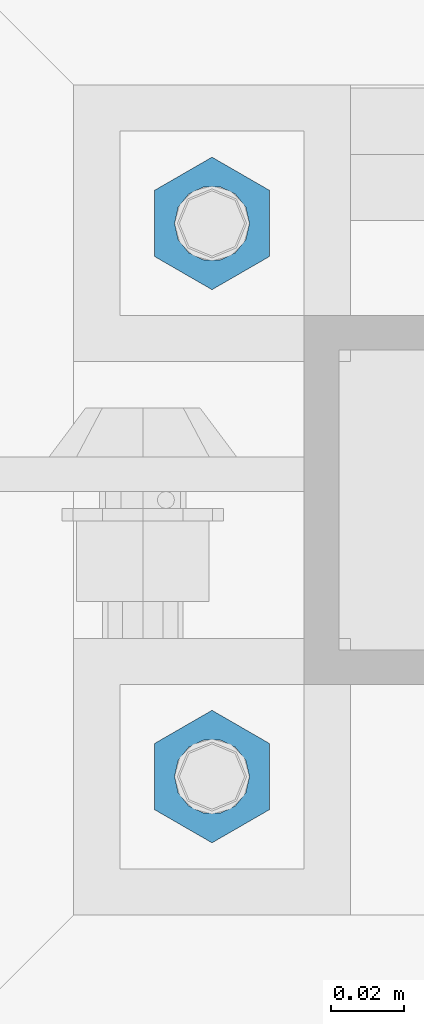
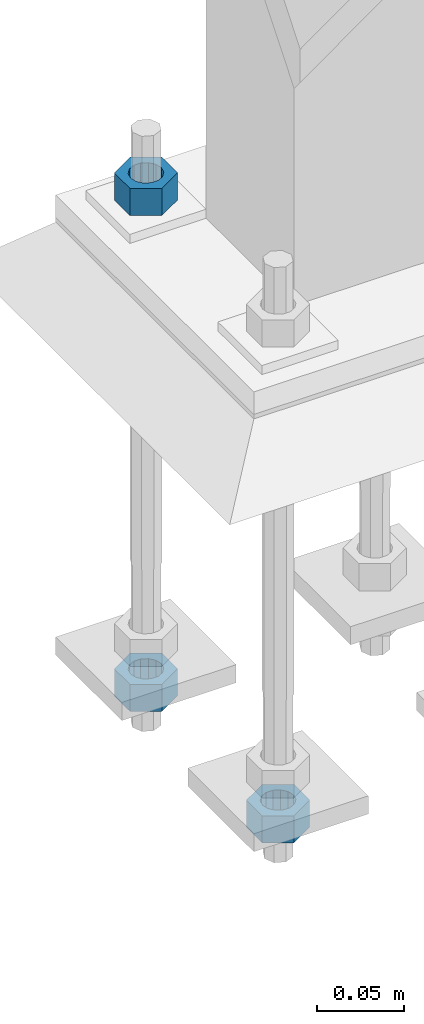
# One storey, part 1676 of 3843: 3 columns, 1 element without a shape of its own.
"""IFC2X3 building model written with IfcOpenShell, lengths in millimetres."""

from ifc_helpers import new_model, si_unit, frame, origin_with_axes, place, context, subcontext, project, spatial, faceted_brep, material, type_object, element, aggregate, save


model = new_model("IFC2X3")

# Units and contexts
model_context = context("Model", 3, precision=1e-05, world=origin_with_axes())
body_context = subcontext(model_context, "Body", "Model", "MODEL_VIEW")
ifc_project = project(units=[si_unit("LENGTHUNIT", "METRE", prefix="MILLI"), si_unit("AREAUNIT", "SQUARE_METRE"), si_unit("VOLUMEUNIT", "CUBIC_METRE"), si_unit("MASSUNIT", "GRAM", prefix="KILO"), si_unit("TIMEUNIT", "SECOND"), si_unit("PLANEANGLEUNIT", "RADIAN"), si_unit("SOLIDANGLEUNIT", "STERADIAN"), si_unit("THERMODYNAMICTEMPERATUREUNIT", "DEGREE_CELSIUS"), si_unit("LUMINOUSINTENSITYUNIT", "LUMEN")], contexts=[model_context])

# Site, building, storey
site_placement = place(None, origin_with_axes())
site = spatial("IfcSite", under=ifc_project, at=site_placement, CompositionType="ELEMENT")
building_placement = place(site_placement, origin_with_axes())
building = spatial("IfcBuilding", under=site, at=building_placement, Name="Undefined", CompositionType="ELEMENT")
storey_placement = place(building_placement, origin_with_axes())
storey = spatial("IfcBuildingStorey", under=building, at=storey_placement, Name="Undefined", CompositionType="ELEMENT", Elevation=0.0)

# Assembly, columns
assembly_placement = place(storey_placement, origin_with_axes())
assembly = element("IfcElementAssembly", 1, at=assembly_placement, inside=storey, Name="TEMPLATE", AssemblyPlace="NOTDEFINED", PredefinedType="RIGID_FRAME")
ifc_material = material(Name="STEEL/A36")
column_type = type_object("IfcColumnType", Name="3/4_HEAVY_HEX_NUT", PredefinedType="NOTDEFINED")
column_1_placement = place(assembly_placement, frame((38744.525, 33769.3, 29756.1), z_axis=(1.0, 0.0, 0.0), x_axis=(0.0, 0.0, -1.0)))
column_1 = element("IfcColumn", 2, at=column_1_placement, type_object=column_type, material=ifc_material, Name="NUT", ObjectType="3/4_HEAVY_HEX_NUT", context=body_context, shape_type="Brep", body=[
    faceted_brep([(0.0, -18.2600002288818, 0.0), (0.0, -9.13000011444092, -15.8100004196167), (19.0500000000029, -9.13000011444092, -15.8100004196167), (19.0500000000029, -18.2600002288818, 0.0), (0.0, 9.13000011444092, -15.8100004196167), (19.0500000000029, 9.13000011444092, -15.8100004196167), (0.0, 18.2600002288818, 0.0), (19.0500000000029, 18.2600002288818, 0.0), (0.0, 9.13000011444092, 15.8100004196167), (19.0500000000029, 9.13000011444092, 15.8100004196167), (0.0, -9.13000011444092, 15.8100004196167), (19.0500000000029, -9.13000011444092, 15.8100004196167), (0.0, 0.0, 10.3199996948242), (0.0, 4.47768005527905, 9.29799844179797), (19.0500000000029, 4.47768005527905, 9.29799844179797), (19.0500000000029, 0.0, 10.3199996948242), (0.0, 8.06850066047627, 6.43441456490837), (19.0500000000029, 8.06850066047627, 6.43441456490837), (0.0, 10.0612557561908, 2.2964159705225), (19.0500000000029, 10.0612557561908, 2.2964159705225), (0.0, 10.0612557561908, -2.2964159705225), (19.0500000000029, 10.0612557561908, -2.2964159705225), (0.0, 8.06850066047627, -6.43441456490837), (19.0500000000029, 8.06850066047627, -6.43441456490837), (0.0, 4.47768005527905, -9.29799844179797), (19.0500000000029, 4.47768005527905, -9.29799844179797), (0.0, 0.0, -10.3199996948242), (19.0500000000029, 0.0, -10.3199996948242), (0.0, -4.47768005527905, -9.29799844179797), (19.0500000000029, -4.47768005527905, -9.29799844179797), (0.0, -8.06850066047627, -6.43441456490837), (19.0500000000029, -8.06850066047627, -6.43441456490837), (0.0, -10.0612557561908, -2.2964159705225), (19.0500000000029, -10.0612557561908, -2.2964159705225), (0.0, -10.0612557561908, 2.2964159705225), (19.0500000000029, -10.0612557561908, 2.2964159705225), (0.0, -8.06850066047627, 6.43441456490837), (19.0500000000029, -8.06850066047627, 6.43441456490837), (0.0, -4.47768005527905, 9.29799844179797), (19.0500000000029, -4.47768005527905, 9.29799844179797)], [[[0, 1, 2, 3]], [[1, 4, 5, 2]], [[4, 6, 7, 5]], [[6, 8, 9, 7]], [[8, 10, 11, 9]], [[10, 0, 3, 11]], [[12, 13, 14, 15]], [[13, 16, 17, 14]], [[16, 18, 19, 17]], [[18, 20, 21, 19]], [[20, 22, 23, 21]], [[22, 24, 25, 23]], [[24, 26, 27, 25]], [[26, 28, 29, 27]], [[28, 30, 31, 29]], [[30, 32, 33, 31]], [[32, 34, 35, 33]], [[34, 36, 37, 35]], [[36, 38, 39, 37]], [[38, 12, 15, 39]], [[5, 7, 9, 11, 3, 2], [17, 19, 21, 23, 25, 27, 29, 31, 33, 35, 37, 39, 15, 14]], [[10, 8, 6, 4, 1, 0], [38, 36, 34, 32, 30, 28, 26, 24, 22, 20, 18, 16, 13, 12]]]),
])
column_2_placement = place(assembly_placement, frame((38744.525, 33921.7, 30105.35), z_axis=(-1.0, 0.0, 0.0), x_axis=(0.0, 0.0, -1.0)))
column_2 = element("IfcColumn", 3, at=column_2_placement, type_object=column_type, material=ifc_material, Name="NUT", ObjectType="3/4_HEAVY_HEX_NUT", context=body_context, shape_type="Brep", body=[
    faceted_brep([(0.0, -18.2600002288818, 0.0), (0.0, -9.13000011444092, -15.8100004196167), (19.0500000000029, -9.13000011444092, -15.8100004196167), (19.0500000000029, -18.2600002288818, 0.0), (0.0, 9.13000011444092, -15.8100004196167), (19.0500000000029, 9.13000011444092, -15.8100004196167), (0.0, 18.2600002288818, 0.0), (19.0500000000029, 18.2600002288818, 0.0), (0.0, 9.13000011444092, 15.8100004196167), (19.0500000000029, 9.13000011444092, 15.8100004196167), (0.0, -9.13000011444092, 15.8100004196167), (19.0500000000029, -9.13000011444092, 15.8100004196167), (0.0, 0.0, 10.3199996948242), (0.0, 4.47768005527905, 9.29799844179797), (19.0500000000029, 4.47768005527905, 9.29799844179797), (19.0500000000029, 0.0, 10.3199996948242), (0.0, 8.06850066047627, 6.43441456490837), (19.0500000000029, 8.06850066047627, 6.43441456490837), (0.0, 10.0612557561908, 2.2964159705225), (19.0500000000029, 10.0612557561908, 2.2964159705225), (0.0, 10.0612557561908, -2.2964159705225), (19.0500000000029, 10.0612557561908, -2.2964159705225), (0.0, 8.06850066047627, -6.43441456490837), (19.0500000000029, 8.06850066047627, -6.43441456490837), (0.0, 4.47768005527905, -9.29799844179797), (19.0500000000029, 4.47768005527905, -9.29799844179797), (0.0, 0.0, -10.3199996948242), (19.0500000000029, 0.0, -10.3199996948242), (0.0, -4.47768005527905, -9.29799844179797), (19.0500000000029, -4.47768005527905, -9.29799844179797), (0.0, -8.06850066047627, -6.43441456490837), (19.0500000000029, -8.06850066047627, -6.43441456490837), (0.0, -10.0612557561908, -2.2964159705225), (19.0500000000029, -10.0612557561908, -2.2964159705225), (0.0, -10.0612557561908, 2.2964159705225), (19.0500000000029, -10.0612557561908, 2.2964159705225), (0.0, -8.06850066047627, 6.43441456490837), (19.0500000000029, -8.06850066047627, 6.43441456490837), (0.0, -4.47768005527905, 9.29799844179797), (19.0500000000029, -4.47768005527905, 9.29799844179797)], [[[0, 1, 2, 3]], [[1, 4, 5, 2]], [[4, 6, 7, 5]], [[6, 8, 9, 7]], [[8, 10, 11, 9]], [[10, 0, 3, 11]], [[12, 13, 14, 15]], [[13, 16, 17, 14]], [[16, 18, 19, 17]], [[18, 20, 21, 19]], [[20, 22, 23, 21]], [[22, 24, 25, 23]], [[24, 26, 27, 25]], [[26, 28, 29, 27]], [[28, 30, 31, 29]], [[30, 32, 33, 31]], [[32, 34, 35, 33]], [[34, 36, 37, 35]], [[36, 38, 39, 37]], [[38, 12, 15, 39]], [[5, 7, 9, 11, 3, 2], [17, 19, 21, 23, 25, 27, 29, 31, 33, 35, 37, 39, 15, 14]], [[10, 8, 6, 4, 1, 0], [38, 36, 34, 32, 30, 28, 26, 24, 22, 20, 18, 16, 13, 12]]]),
])
column_3_placement = place(assembly_placement, frame((38744.525, 33921.7, 29756.1), z_axis=(-1.0, 0.0, 0.0), x_axis=(0.0, 0.0, -1.0)))
column_3 = element("IfcColumn", 4, at=column_3_placement, type_object=column_type, material=ifc_material, Name="NUT", ObjectType="3/4_HEAVY_HEX_NUT", context=body_context, shape_type="Brep", body=[
    faceted_brep([(0.0, -18.2600002288818, 0.0), (0.0, -9.13000011444092, -15.8100004196167), (19.0500000000029, -9.13000011444092, -15.8100004196167), (19.0500000000029, -18.2600002288818, 0.0), (0.0, 9.13000011444092, -15.8100004196167), (19.0500000000029, 9.13000011444092, -15.8100004196167), (0.0, 18.2600002288818, 0.0), (19.0500000000029, 18.2600002288818, 0.0), (0.0, 9.13000011444092, 15.8100004196167), (19.0500000000029, 9.13000011444092, 15.8100004196167), (0.0, -9.13000011444092, 15.8100004196167), (19.0500000000029, -9.13000011444092, 15.8100004196167), (0.0, 0.0, 10.3199996948242), (0.0, 4.47768005527905, 9.29799844179797), (19.0500000000029, 4.47768005527905, 9.29799844179797), (19.0500000000029, 0.0, 10.3199996948242), (0.0, 8.06850066047627, 6.43441456490837), (19.0500000000029, 8.06850066047627, 6.43441456490837), (0.0, 10.0612557561908, 2.2964159705225), (19.0500000000029, 10.0612557561908, 2.2964159705225), (0.0, 10.0612557561908, -2.2964159705225), (19.0500000000029, 10.0612557561908, -2.2964159705225), (0.0, 8.06850066047627, -6.43441456490837), (19.0500000000029, 8.06850066047627, -6.43441456490837), (0.0, 4.47768005527905, -9.29799844179797), (19.0500000000029, 4.47768005527905, -9.29799844179797), (0.0, 0.0, -10.3199996948242), (19.0500000000029, 0.0, -10.3199996948242), (0.0, -4.47768005527905, -9.29799844179797), (19.0500000000029, -4.47768005527905, -9.29799844179797), (0.0, -8.06850066047627, -6.43441456490837), (19.0500000000029, -8.06850066047627, -6.43441456490837), (0.0, -10.0612557561908, -2.2964159705225), (19.0500000000029, -10.0612557561908, -2.2964159705225), (0.0, -10.0612557561908, 2.2964159705225), (19.0500000000029, -10.0612557561908, 2.2964159705225), (0.0, -8.06850066047627, 6.43441456490837), (19.0500000000029, -8.06850066047627, 6.43441456490837), (0.0, -4.47768005527905, 9.29799844179797), (19.0500000000029, -4.47768005527905, 9.29799844179797)], [[[0, 1, 2, 3]], [[1, 4, 5, 2]], [[4, 6, 7, 5]], [[6, 8, 9, 7]], [[8, 10, 11, 9]], [[10, 0, 3, 11]], [[12, 13, 14, 15]], [[13, 16, 17, 14]], [[16, 18, 19, 17]], [[18, 20, 21, 19]], [[20, 22, 23, 21]], [[22, 24, 25, 23]], [[24, 26, 27, 25]], [[26, 28, 29, 27]], [[28, 30, 31, 29]], [[30, 32, 33, 31]], [[32, 34, 35, 33]], [[34, 36, 37, 35]], [[36, 38, 39, 37]], [[38, 12, 15, 39]], [[5, 7, 9, 11, 3, 2], [17, 19, 21, 23, 25, 27, 29, 31, 33, 35, 37, 39, 15, 14]], [[10, 8, 6, 4, 1, 0], [38, 36, 34, 32, 30, 28, 26, 24, 22, 20, 18, 16, 13, 12]]]),
])
aggregate(assembly, [column_1, column_2, column_3])

save(model, "model.ifc")
